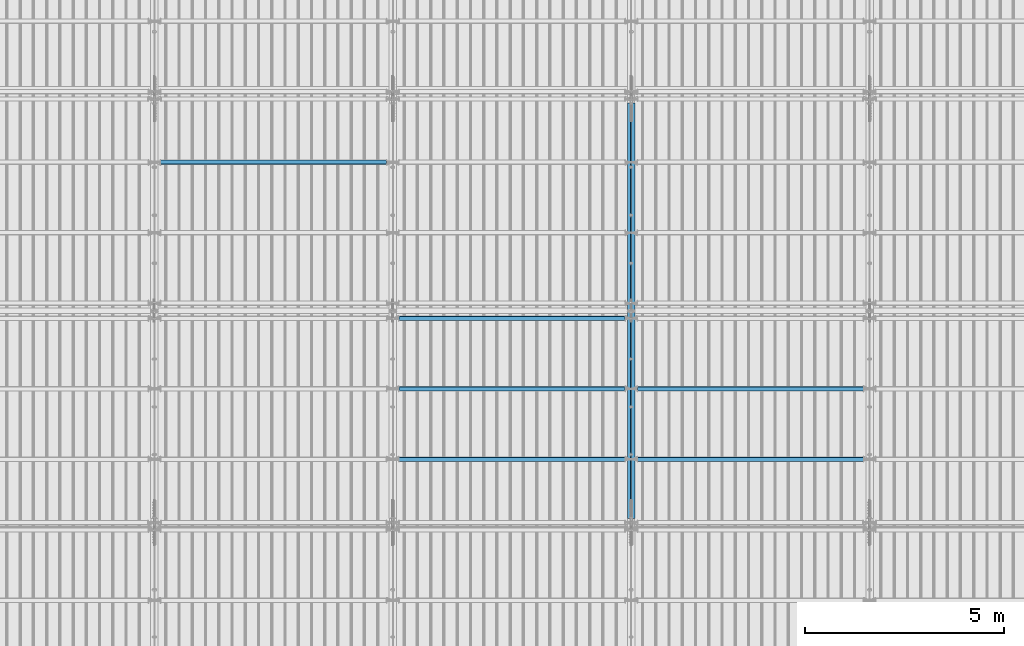
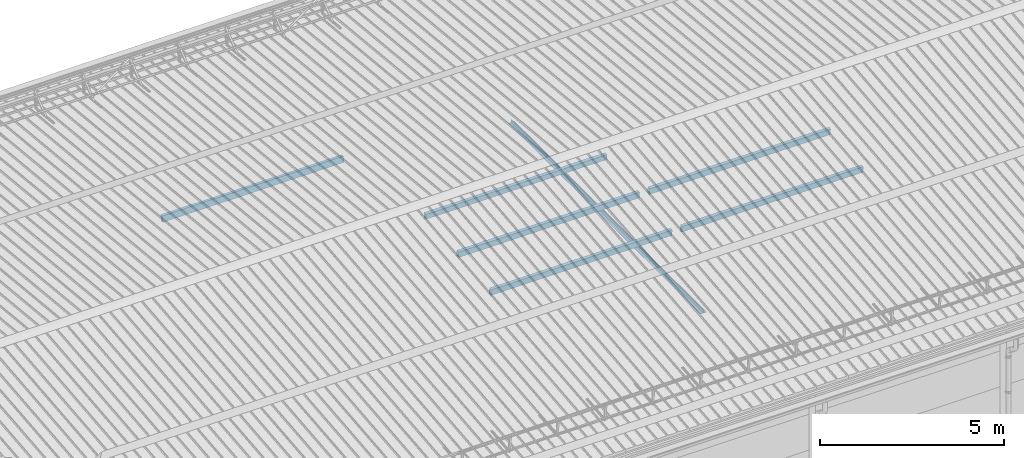
# One storey, part 260 of 709: 8 beams, 8 elements without a shape of their own.
"""IFC4 building model written with IfcOpenShell, lengths in millimetres."""

from ifc_helpers import new_model, si_unit, direction, frame, origin_with_axes, place, context, subcontext, project, spatial, polygons, material, element, aggregate, save


model = new_model("IFC4")

# Units and contexts
model_context = context("Model", 3, precision=0.2, world=origin_with_axes(), true_north=direction((0.0, 1.0)))
body_context = subcontext(model_context, "Body", "Model", "MODEL_VIEW")
ifc_project = project(units=[si_unit("LENGTHUNIT", "METRE", prefix="MILLI"), si_unit("AREAUNIT", "SQUARE_METRE"), si_unit("VOLUMEUNIT", "CUBIC_METRE"), si_unit("MASSUNIT", "GRAM", prefix="KILO"), si_unit("TIMEUNIT", "SECOND"), si_unit("PLANEANGLEUNIT", "RADIAN"), si_unit("SOLIDANGLEUNIT", "STERADIAN"), si_unit("THERMODYNAMICTEMPERATUREUNIT", "DEGREE_CELSIUS"), si_unit("LUMINOUSINTENSITYUNIT", "LUMEN")], contexts=[model_context])

# Site, building, storey
site_placement = place(None, origin_with_axes())
site = spatial("IfcSite", under=ifc_project, at=site_placement, CompositionType="ELEMENT")
building_placement = place(site_placement, origin_with_axes())
building = spatial("IfcBuilding", under=site, at=building_placement, Name="Undefined", CompositionType="ELEMENT")
storey_placement = place(building_placement, origin_with_axes())
storey = spatial("IfcBuildingStorey", under=building, at=storey_placement, Name="Undefined", CompositionType="ELEMENT", Elevation=0.0)

# Assembly, beam
assembly_1_placement = place(storey_placement, frame((27949.0, 5673.0, 6045.00002), z_axis=(0.0, 0.0, 1.0), x_axis=(0.0, 1.0, 0.0)))
assembly_1 = element("IfcElementAssembly", 1, at=assembly_1_placement, inside=storey)
ifc_material_1 = material(Name="C345-5", Category="STEEL")
beam_1_placement = place(assembly_1_placement, origin_with_axes())
beam_1 = element("IfcBeam", 2, at=beam_1_placement, material=ifc_material_1, ObjectType="433", context=body_context, shape_type="Tessellation", body=[
    polygons([(100.0, -45.0, -45.0), (100.0, 45.0, -45.0), (10554.0, 45.0, -45.0), (10554.0, -45.0, -45.0), (100.0, 45.0, -39.0), (10554.0, 45.0, -39.0), (100.0, -39.0, -39.0), (10554.0, -39.0, -39.0), (100.0, -39.0, 45.0), (10554.0, -39.0, 45.0), (100.0, -45.0, 45.0), (10554.0, -45.0, 45.0)], [[[1, 2, 3, 4]], [[2, 5, 6, 3]], [[5, 7, 8, 6]], [[7, 9, 10, 8]], [[9, 11, 12, 10]], [[11, 1, 4, 12]], [[6, 8, 10, 12, 4, 3]], [[11, 9, 7, 5, 2, 1]]], closed=True),
])
aggregate(assembly_1, [beam_1])

assembly_2_placement = place(storey_placement, frame((28051.0, 16327.0, 6045.00002), z_axis=(0.0, 0.0, 1.0), x_axis=(0.0, -1.0, 0.0)))
assembly_2 = element("IfcElementAssembly", 3, at=assembly_2_placement, inside=storey)
beam_2_placement = place(assembly_2_placement, origin_with_axes())
beam_2 = element("IfcBeam", 4, at=beam_2_placement, material=ifc_material_1, ObjectType="434", context=body_context, shape_type="Tessellation", body=[
    polygons([(100.0, -45.0, -45.0), (100.0, 45.0, -45.0), (10554.0, 45.0, -45.0), (10554.0, -45.0, -45.0), (100.0, 45.0, -39.0), (10554.0, 45.0, -39.0), (100.0, -39.0, -39.0), (10554.0, -39.0, -39.0), (100.0, -39.0, 45.0), (10554.0, -39.0, 45.0), (100.0, -45.0, 45.0), (10554.0, -45.0, 45.0)], [[[1, 2, 3, 4]], [[2, 5, 6, 3]], [[5, 7, 8, 6]], [[7, 9, 10, 8]], [[9, 11, 12, 10]], [[11, 1, 4, 12]], [[6, 8, 10, 12, 4, 3]], [[11, 9, 7, 5, 2, 1]]], closed=True),
])
aggregate(assembly_2, [beam_2])

assembly_3_placement = place(storey_placement, frame((22000.0, 14736.65012, 7854.7991), z_axis=(0.0, -0.9950371902, 0.099503719), x_axis=(-1.0, 0.0, 0.0)))
assembly_3 = element("IfcElementAssembly", 5, at=assembly_3_placement, inside=storey)
ifc_material_2 = material(Name="C355", Category="STEEL")
beam_3_placement = place(assembly_3_placement, origin_with_axes())
beam_3 = element("IfcBeam", 6, at=beam_3_placement, material=ifc_material_2, ObjectType="579", context=body_context, shape_type="Tessellation", body=[
    polygons([(155.0, -96.0, -46.0), (155.0, -96.0, 46.0), (5845.0, -96.0, 46.0), (5845.0, -96.0, -46.0), (155.0, 96.0, 46.0), (5845.0, 96.0, 46.0), (155.0, 96.0, -46.0), (5845.0, 96.0, -46.0), (155.0, -100.0, -50.0), (155.0, 100.0, -50.0), (5845.0, 100.0, -50.0), (5845.0, -100.0, -50.0), (155.0, 100.0, 50.0), (5845.0, 100.0, 50.0), (155.0, -100.0, 50.0), (5845.0, -100.0, 50.0)], [[[1, 2, 3, 4]], [[2, 5, 6, 3]], [[5, 7, 8, 6]], [[7, 1, 4, 8]], [[9, 10, 11, 12]], [[10, 13, 14, 11]], [[13, 15, 16, 14]], [[15, 9, 12, 16]], [[14, 16, 12, 11], [6, 8, 4, 3]], [[15, 13, 10, 9], [7, 5, 2, 1]]], closed=True),
])
aggregate(assembly_3, [beam_3])

assembly_4_placement = place(storey_placement, frame((22000.0, 7263.34988, 7854.7991), z_axis=(0.0, 0.9950371902, 0.099503719), x_axis=(1.0, 0.0, 0.0)))
assembly_4 = element("IfcElementAssembly", 7, at=assembly_4_placement, inside=storey)
beam_4_placement = place(assembly_4_placement, origin_with_axes())
beam_4 = element("IfcBeam", 8, at=beam_4_placement, material=ifc_material_2, ObjectType="579", context=body_context, shape_type="Tessellation", body=[
    polygons([(155.0, -96.0, -46.0), (155.0, -96.0, 46.0), (5845.0, -96.0, 46.0), (5845.0, -96.0, -46.0), (155.0, 96.0, 46.0), (5845.0, 96.0, 46.0), (155.0, 96.0, -46.0), (5845.0, 96.0, -46.0), (155.0, -100.0, -50.0), (155.0, 100.0, -50.0), (5845.0, 100.0, -50.0), (5845.0, -100.0, -50.0), (155.0, 100.0, 50.0), (5845.0, 100.0, 50.0), (155.0, -100.0, 50.0), (5845.0, -100.0, 50.0)], [[[1, 2, 3, 4]], [[2, 5, 6, 3]], [[5, 7, 8, 6]], [[7, 1, 4, 8]], [[9, 10, 11, 12]], [[10, 13, 14, 11]], [[13, 15, 16, 14]], [[15, 9, 12, 16]], [[14, 16, 12, 11], [6, 8, 4, 3]], [[15, 13, 10, 9], [7, 5, 2, 1]]], closed=True),
])
aggregate(assembly_4, [beam_4])

assembly_5_placement = place(storey_placement, frame((22000.0, 9036.65012, 8032.12913), z_axis=(0.0, 0.9950371902, 0.099503719), x_axis=(1.0, 0.0, 0.0)))
assembly_5 = element("IfcElementAssembly", 9, at=assembly_5_placement, inside=storey)
beam_5_placement = place(assembly_5_placement, origin_with_axes())
beam_5 = element("IfcBeam", 10, at=beam_5_placement, material=ifc_material_2, ObjectType="579", context=body_context, shape_type="Tessellation", body=[
    polygons([(155.0, -96.0, -46.0), (155.0, -96.0, 46.0), (5845.0, -96.0, 46.0), (5845.0, -96.0, -46.0), (155.0, 96.0, 46.0), (5845.0, 96.0, 46.0), (155.0, 96.0, -46.0), (5845.0, 96.0, -46.0), (155.0, -100.0, -50.0), (155.0, 100.0, -50.0), (5845.0, 100.0, -50.0), (5845.0, -100.0, -50.0), (155.0, 100.0, 50.0), (5845.0, 100.0, 50.0), (155.0, -100.0, 50.0), (5845.0, -100.0, 50.0)], [[[1, 2, 3, 4]], [[2, 5, 6, 3]], [[5, 7, 8, 6]], [[7, 1, 4, 8]], [[9, 10, 11, 12]], [[10, 13, 14, 11]], [[13, 15, 16, 14]], [[15, 9, 12, 16]], [[14, 16, 12, 11], [6, 8, 4, 3]], [[15, 13, 10, 9], [7, 5, 2, 1]]], closed=True),
])
aggregate(assembly_5, [beam_5])

assembly_6_placement = place(storey_placement, frame((22000.0, 10808.95533, 8219.40952), z_axis=(0.0, 0.9950371902, 0.099503719), x_axis=(1.0, 0.0, 0.0)))
assembly_6 = element("IfcElementAssembly", 11, at=assembly_6_placement, inside=storey)
beam_6_placement = place(assembly_6_placement, origin_with_axes())
beam_6 = element("IfcBeam", 12, at=beam_6_placement, material=ifc_material_2, ObjectType="580", context=body_context, shape_type="Tessellation", body=[
    polygons([(155.0, -86.0, -46.0), (155.0, -86.0, 46.0), (5845.0, -86.0, 46.0), (5845.0, -86.0, -46.0), (155.0, 86.0, 46.0), (5845.0, 86.0, 46.0), (155.0, 86.0, -46.0), (5845.0, 86.0, -46.0), (155.0, -90.0, -50.0), (155.0, 90.0, -50.0), (5845.0, 90.0, -50.0), (5845.0, -90.0, -50.0), (155.0, 90.0, 50.0), (5845.0, 90.0, 50.0), (155.0, -90.0, 50.0), (5845.0, -90.0, 50.0)], [[[1, 2, 3, 4]], [[2, 5, 6, 3]], [[5, 7, 8, 6]], [[7, 1, 4, 8]], [[9, 10, 11, 12]], [[10, 13, 14, 11]], [[13, 15, 16, 14]], [[15, 9, 12, 16]], [[14, 16, 12, 11], [6, 8, 4, 3]], [[15, 13, 10, 9], [7, 5, 2, 1]]], closed=True),
])
aggregate(assembly_6, [beam_6])

assembly_7_placement = place(storey_placement, frame((28000.0, 7263.34988, 7854.7991), z_axis=(0.0, 0.9950371902, 0.099503719), x_axis=(1.0, 0.0, 0.0)))
assembly_7 = element("IfcElementAssembly", 13, at=assembly_7_placement, inside=storey)
beam_7_placement = place(assembly_7_placement, origin_with_axes())
beam_7 = element("IfcBeam", 14, at=beam_7_placement, material=ifc_material_2, ObjectType="579", context=body_context, shape_type="Tessellation", body=[
    polygons([(155.0, -96.0, -46.0), (155.0, -96.0, 46.0), (5845.0, -96.0, 46.0), (5845.0, -96.0, -46.0), (155.0, 96.0, 46.0), (5845.0, 96.0, 46.0), (155.0, 96.0, -46.0), (5845.0, 96.0, -46.0), (155.0, -100.0, -50.0), (155.0, 100.0, -50.0), (5845.0, 100.0, -50.0), (5845.0, -100.0, -50.0), (155.0, 100.0, 50.0), (5845.0, 100.0, 50.0), (155.0, -100.0, 50.0), (5845.0, -100.0, 50.0)], [[[1, 2, 3, 4]], [[2, 5, 6, 3]], [[5, 7, 8, 6]], [[7, 1, 4, 8]], [[9, 10, 11, 12]], [[10, 13, 14, 11]], [[13, 15, 16, 14]], [[15, 9, 12, 16]], [[14, 16, 12, 11], [6, 8, 4, 3]], [[15, 13, 10, 9], [7, 5, 2, 1]]], closed=True),
])
aggregate(assembly_7, [beam_7])

assembly_8_placement = place(storey_placement, frame((28000.0, 9036.65012, 8032.12913), z_axis=(0.0, 0.9950371902, 0.099503719), x_axis=(1.0, 0.0, 0.0)))
assembly_8 = element("IfcElementAssembly", 15, at=assembly_8_placement, inside=storey)
beam_8_placement = place(assembly_8_placement, origin_with_axes())
beam_8 = element("IfcBeam", 16, at=beam_8_placement, material=ifc_material_2, ObjectType="579", context=body_context, shape_type="Tessellation", body=[
    polygons([(155.0, -96.0, -46.0), (155.0, -96.0, 46.0), (5845.0, -96.0, 46.0), (5845.0, -96.0, -46.0), (155.0, 96.0, 46.0), (5845.0, 96.0, 46.0), (155.0, 96.0, -46.0), (5845.0, 96.0, -46.0), (155.0, -100.0, -50.0), (155.0, 100.0, -50.0), (5845.0, 100.0, -50.0), (5845.0, -100.0, -50.0), (155.0, 100.0, 50.0), (5845.0, 100.0, 50.0), (155.0, -100.0, 50.0), (5845.0, -100.0, 50.0)], [[[1, 2, 3, 4]], [[2, 5, 6, 3]], [[5, 7, 8, 6]], [[7, 1, 4, 8]], [[9, 10, 11, 12]], [[10, 13, 14, 11]], [[13, 15, 16, 14]], [[15, 9, 12, 16]], [[14, 16, 12, 11], [6, 8, 4, 3]], [[15, 13, 10, 9], [7, 5, 2, 1]]], closed=True),
])
aggregate(assembly_8, [beam_8])

save(model, "model.ifc")
